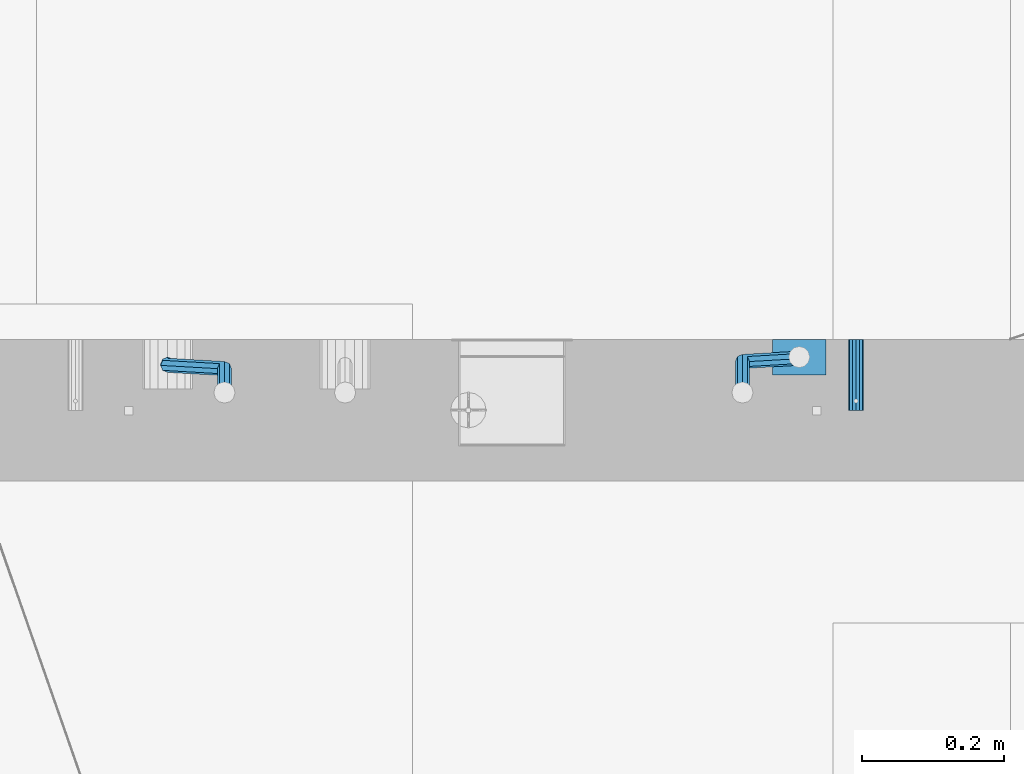
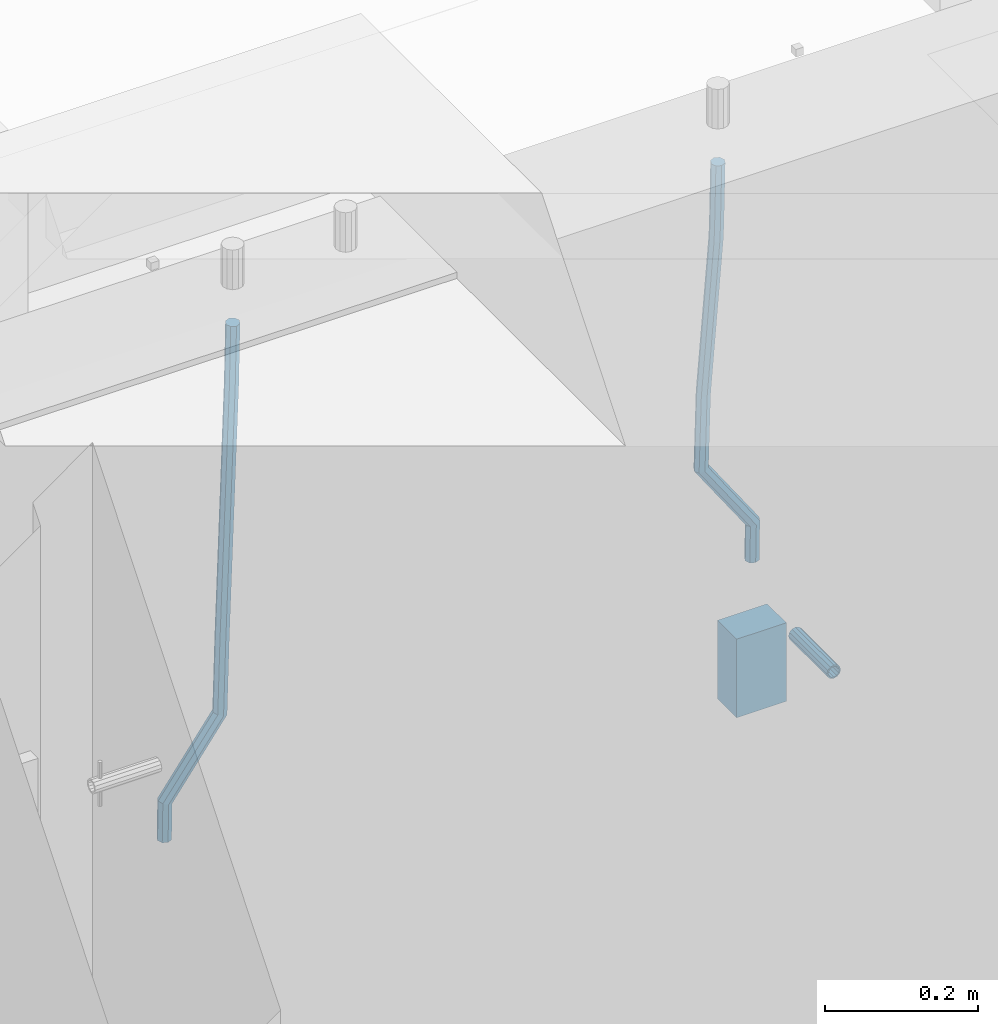
# One storey, part 164 of 352: 4 beams, 2 elements without a shape of their own.
"""IFC2X3 building model written with IfcOpenShell, lengths in millimetres."""

import ifcopenshell
import ifcopenshell.guid

model = None  # the IFC model being written
_history = None  # IfcOwnerHistory: only IFC2X3 demands one
_inside = {}  # id of a spatial element -> (the spatial element, [elements in it])
_under = {}  # id of a project, library or spatial element -> (it, [spatial elements below it])
_declared = {}  # id of a project -> (the project, [libraries it declares])
_typed = {}  # id of a type object -> (the type object, [elements of that type])
_made_of = {}  # id of a material, layer set ... -> (it, [elements and type objects made of it])


def new_model(schema):
    """Start an empty IFC model of exactly this schema.

    Asked for "IFC4X3", IfcOpenShell would pick the latest addendum, in which some entities
    have other attributes; the version numbers below select the first issue.
    IFC2X3 requires an IfcOwnerHistory on every rooted entity: one is made here for all.
    """
    global model, _history
    if schema == "IFC4X3":
        model = ifcopenshell.file(schema_version=(4, 3, 0, 0))
    else:
        model = ifcopenshell.file(schema=schema)
    _inside.clear()
    _under.clear()
    _declared.clear()
    _typed.clear()
    _made_of.clear()
    _history = None
    if model.schema == "IFC2X3":
        org = make("IfcOrganization", Name="unknown")
        user = make(
            "IfcPersonAndOrganization",
            ThePerson=make("IfcPerson", FamilyName="unknown"),
            TheOrganization=org,
        )
        app = make(
            "IfcApplication",
            ApplicationDeveloper=org,
            Version="unknown",
            ApplicationFullName="unknown",
            ApplicationIdentifier="unknown",
        )
        _history = make(
            "IfcOwnerHistory",
            OwningUser=user,
            OwningApplication=app,
            ChangeAction="ADDED",
            CreationDate=0,
        )
    return model


def make(cls, **values):
    """One entity of the class cls with the attributes given. An attribute that is None is left unset."""
    return model.create_entity(
        cls, **{name: value for name, value in values.items() if value is not None}
    )


def rooted(cls, **values):
    """An entity with a GlobalId (a new one), such as an element, a storey or a relation."""
    return make(cls, GlobalId=ifcopenshell.guid.new(), OwnerHistory=_history, **values)


def si_unit(unit_type, name, prefix=None):
    """IfcSIUnit, for example si_unit("LENGTHUNIT", "METRE", prefix="MILLI")."""
    return make("IfcSIUnit", UnitType=unit_type, Prefix=prefix, Name=name)


def assignment(units):
    """IfcUnitAssignment: the units of a project."""
    return None if units is None else make("IfcUnitAssignment", Units=units)


def point(xyz):
    """IfcCartesianPoint."""
    return None if xyz is None else make("IfcCartesianPoint", Coordinates=xyz)


def direction(xyz):
    """IfcDirection."""
    return None if xyz is None else make("IfcDirection", DirectionRatios=xyz)


def frame(location, z_axis=None, x_axis=None):
    """IfcAxis2Placement3D, a coordinate frame: its origin and axes. An axis left out is left unset."""
    return make(
        "IfcAxis2Placement3D",
        Location=point(location),
        Axis=direction(z_axis),
        RefDirection=direction(x_axis),
    )


def origin_with_axes():
    """The frame at (0, 0, 0) with the z axis (0, 0, 1) and the x axis (1, 0, 0) written out."""
    return frame((0.0, 0.0, 0.0), z_axis=(0.0, 0.0, 1.0), x_axis=(1.0, 0.0, 0.0))


def place(relative_to, where):
    """IfcLocalPlacement: puts the frame where relative to a parent placement (None: the world)."""
    return make(
        "IfcLocalPlacement", PlacementRelTo=relative_to, RelativePlacement=where
    )


def context(
    kind, dimensions, precision=None, world=None, true_north=None, identifier=None
):
    """IfcGeometricRepresentationContext, for example the 3D "Model" context."""
    return make(
        "IfcGeometricRepresentationContext",
        ContextIdentifier=identifier,
        ContextType=kind,
        CoordinateSpaceDimension=dimensions,
        Precision=precision,
        WorldCoordinateSystem=world,
        TrueNorth=true_north,
    )


def subcontext(parent, identifier, kind, view, scale=None):
    """IfcGeometricRepresentationSubContext, for example "Body" below "Model"."""
    return make(
        "IfcGeometricRepresentationSubContext",
        ContextIdentifier=identifier,
        ContextType=kind,
        ParentContext=parent,
        TargetScale=scale,
        TargetView=view,
    )


def project(units=None, contexts=None):
    """IfcProject with its units and contexts."""
    return rooted(
        "IfcProject",
        Name="project",
        RepresentationContexts=contexts,
        UnitsInContext=assignment(units),
    )


def spatial(cls, under=None, at=None, **own):
    """A site, building, storey or space (cls), placed at a placement, below another one or the project."""
    s = rooted(cls, ObjectPlacement=at, **own)
    if under is not None:
        _under.setdefault(under.id(), (under, []))[1].append(s)
    return s


def faces_of(points, faces, orient=None, outer=None):
    """IfcFace entities. A face is a list of loops; a loop is a list of indices into points, from 0.

    orient and outer hold one flag for each loop. By default every Orientation is true, the
    first loop of a face is its IfcFaceOuterBound and the others are IfcFaceBound.
    """
    made = []
    for i, loops in enumerate(faces):
        bounds = []
        for j, loop in enumerate(loops):
            is_outer = j == 0 if outer is None else outer[i][j]
            bounds.append(
                make(
                    "IfcFaceOuterBound" if is_outer else "IfcFaceBound",
                    Bound=make("IfcPolyLoop", Polygon=[points[k] for k in loop]),
                    Orientation=True if orient is None else orient[i][j],
                )
            )
        made.append(make("IfcFace", Bounds=bounds))
    return made


def faceted_brep(points, faces, orient=None, outer=None, voids=None):
    """IfcFacetedBrep: a solid bounded by flat faces; with voids (closed shells), ...WithVoids."""
    shared = [point(p) for p in points]
    hull = make("IfcClosedShell", CfsFaces=faces_of(shared, faces, orient, outer))
    if voids is None:
        return make("IfcFacetedBrep", Outer=hull)
    return make(
        "IfcFacetedBrepWithVoids",
        Outer=hull,
        Voids=[
            make(cls, CfsFaces=faces_of(shared, fs, o, b)) for cls, fs, o, b in voids
        ],
    )


def shape(context_of_items, identifier, shape_type, items):
    """IfcShapeRepresentation: the items that make up one representation, for example the "Body"."""
    return make(
        "IfcShapeRepresentation",
        ContextOfItems=context_of_items,
        RepresentationIdentifier=identifier,
        RepresentationType=shape_type,
        Items=items,
    )


def material(Name=None, Category=None):
    """IfcMaterial."""
    return make("IfcMaterial", Name=Name, Category=Category)


def made_of(thing, what):
    """Note that an element or type object is made of a material, layer set ...; save() writes the relation."""
    if what is not None:
        _made_of.setdefault(what.id(), (what, []))[1].append(thing)
    return thing


def type_object(cls, material=None, **own):
    """A type object (cls), such as IfcWallType, which elements share."""
    return made_of(rooted(cls, **own), material)


def element(
    cls,
    number,
    at=None,
    inside=None,
    cuts=None,
    type_object=None,
    material=None,
    context=None,
    identifier="Body",
    shape_type=None,
    held_by="IfcProductDefinitionShape",
    body=None,
    shapes=None,
    **own,
):
    """One element of the class cls, such as IfcWall. Its Tag is "e" and its number.

    at: its placement. inside: the storey or other place that contains it. cuts: it is an
    opening in that element (IfcRelVoidsElement). A single representation is given by context,
    identifier, shape_type and body (its items); several are given by shapes. held_by: the class
    of the entity that holds the representations. save() writes the other relations.
    """
    e = rooted(cls, Tag="e%d" % number, ObjectPlacement=at, **own)
    if body is not None:
        shapes = [shape(context, identifier, shape_type, body)]
    if shapes is not None:
        e.Representation = make(held_by, Representations=shapes)
    if inside is not None:
        _inside.setdefault(inside.id(), (inside, []))[1].append(e)
    if cuts is not None:
        rooted(
            "IfcRelVoidsElement", RelatingBuildingElement=cuts, RelatedOpeningElement=e
        )
    if type_object is not None:
        _typed.setdefault(type_object.id(), (type_object, []))[1].append(e)
    return made_of(e, material)


def aggregate(whole, parts):
    """IfcRelAggregates: a whole, such as a stair, and the parts it consists of."""
    return rooted("IfcRelAggregates", RelatingObject=whole, RelatedObjects=parts)


def save(model, path):
    """Write the relations noted so far, then the file.

    IfcRelAggregates (storeys below a building ...), IfcRelContainedInSpatialStructure (elements
    in a storey), IfcRelDefinesByType, IfcRelAssociatesMaterial and IfcRelDeclares: one each for
    every whole, place, type object, material and project.
    """
    for whole, parts in _under.values():
        aggregate(whole, parts)
    for where, things in _inside.values():
        rooted(
            "IfcRelContainedInSpatialStructure",
            RelatedElements=things,
            RelatingStructure=where,
        )
    for kind, things in _typed.values():
        rooted("IfcRelDefinesByType", RelatedObjects=things, RelatingType=kind)
    for what, things in _made_of.values():
        rooted("IfcRelAssociatesMaterial", RelatedObjects=things, RelatingMaterial=what)
    for by, libraries in _declared.values():
        rooted("IfcRelDeclares", RelatingContext=by, RelatedDefinitions=libraries)
    model.write(path)


model = new_model("IFC2X3")

# Units and contexts
model_context = context("Model", 3, precision=1e-05, world=origin_with_axes())
body_context = subcontext(model_context, "Body", "Model", "MODEL_VIEW")
ifc_project = project(units=[si_unit("LENGTHUNIT", "METRE", prefix="MILLI"), si_unit("AREAUNIT", "SQUARE_METRE"), si_unit("VOLUMEUNIT", "CUBIC_METRE"), si_unit("MASSUNIT", "GRAM", prefix="KILO"), si_unit("TIMEUNIT", "SECOND"), si_unit("PLANEANGLEUNIT", "RADIAN"), si_unit("SOLIDANGLEUNIT", "STERADIAN"), si_unit("THERMODYNAMICTEMPERATUREUNIT", "DEGREE_CELSIUS"), si_unit("LUMINOUSINTENSITYUNIT", "LUMEN")], contexts=[model_context])

# Site, building, storey
site_placement = place(None, origin_with_axes())
site = spatial("IfcSite", under=ifc_project, at=site_placement, CompositionType="ELEMENT")
building_placement = place(site_placement, origin_with_axes())
building = spatial("IfcBuilding", under=site, at=building_placement, CompositionType="ELEMENT")
storey_placement = place(building_placement, origin_with_axes())
storey = spatial("IfcBuildingStorey", under=building, at=storey_placement, Name="6", CompositionType="ELEMENT", Elevation=0.0)

# Assemblies, beams
assembly_1_placement = place(storey_placement, origin_with_axes())
assembly_1 = element("IfcElementAssembly", 1, at=assembly_1_placement, inside=storey, AssemblyPlace="NOTDEFINED", PredefinedType="REINFORCEMENT_UNIT")
assembly_2_placement = place(assembly_1_placement, origin_with_axes())
assembly_2 = element("IfcElementAssembly", 2, at=assembly_2_placement, Name="Steel Assembly", AssemblyPlace="NOTDEFINED", PredefinedType="RIGID_FRAME")
ifc_material_1 = material(Name="STEEL/Steel_Undefined")
beam_type_1 = type_object("IfcBeamType", PredefinedType="NOTDEFINED")
beam_1_placement = place(assembly_2_placement, frame((27934.9999668009, 17080.0, 98555.0), z_axis=(1.0, 0.0, 0.0), x_axis=(0.0, -1.0, 0.0)))
beam_1 = element("IfcBeam", 3, at=beam_1_placement, type_object=beam_type_1, material=ifc_material_1, Name="M16", context=body_context, shape_type="Brep", body=[
    faceted_brep([(0.0, -8.49999999999272, -1.45519152283669e-11), (0.0, -7.36121593215648, 4.24999999998545), (100.000000000262, -7.36121593215648, 4.24999999998545), (100.000000000262, -8.49999999999272, -1.45519152283669e-11), (0.0, -4.24999999998545, 7.36121593216376), (100.000000000262, -4.24999999998545, 7.36121593216376), (0.0, 1.45519152283669e-11, 8.49999999998545), (100.000000000262, 1.45519152283669e-11, 8.49999999998545), (0.0, 4.25000000001455, 7.36121593216376), (100.000000000262, 4.25000000001455, 7.36121593216376), (0.0, 7.36121593217104, 4.24999999998545), (100.000000000262, 7.36121593217104, 4.24999999998545), (0.0, 8.50000000000728, 0.0), (100.000000000262, 8.50000000000728, 0.0), (0.0, 7.36121593217104, -4.25000000001455), (100.000000000262, 7.36121593217104, -4.25000000001455), (0.0, 4.25000000000728, -7.36121593219286), (100.000000000262, 4.25000000000728, -7.36121593219286), (0.0, 7.27595761418343e-12, -8.5), (100.000000000262, 7.27595761418343e-12, -8.5), (0.0, -4.24999999999272, -7.36121593217831), (100.000000000262, -4.24999999999272, -7.36121593217831), (0.0, -7.36121593215648, -4.25), (100.000000000262, -7.36121593215648, -4.25), (0.0, -10.4999999999927, -1.45519152283669e-11), (0.0, -9.09326673972828, -5.25000000001455), (100.000000000262, -9.09326673972828, -5.25000000001455), (100.000000000262, -10.4999999999927, -1.45519152283669e-11), (0.0, -5.24999999998545, -9.09326673974283), (100.000000000262, -5.24999999998545, -9.09326673974283), (0.0, 7.27595761418343e-12, -10.5), (100.000000000262, 7.27595761418343e-12, -10.5), (0.0, 5.25000000001455, -9.09326673975738), (100.000000000262, 5.25000000001455, -9.09326673975738), (0.0, 9.09326673975011, -5.25000000001455), (100.000000000262, 9.09326673975011, -5.25000000001455), (0.0, 10.5000000000073, -1.45519152283669e-11), (100.000000000262, 10.5000000000073, -1.45519152283669e-11), (0.0, 9.09326673975011, 5.25), (100.000000000262, 9.09326673975011, 5.25), (0.0, 5.25000000000728, 9.09326673972828), (100.000000000262, 5.25000000000728, 9.09326673972828), (0.0, 1.45519152283669e-11, 10.4999999999854), (100.000000000262, 1.45519152283669e-11, 10.4999999999854), (0.0, -5.24999999999272, 9.09326673972828), (100.000000000262, -5.24999999999272, 9.09326673972828), (0.0, -9.09326673972828, 5.24999999998545), (100.000000000262, -9.09326673972828, 5.24999999998545)], [[[0, 1, 2, 3]], [[1, 4, 5, 2]], [[4, 6, 7, 5]], [[6, 8, 9, 7]], [[8, 10, 11, 9]], [[10, 12, 13, 11]], [[12, 14, 15, 13]], [[14, 16, 17, 15]], [[16, 18, 19, 17]], [[18, 20, 21, 19]], [[20, 22, 23, 21]], [[22, 0, 3, 23]], [[24, 25, 26, 27]], [[25, 28, 29, 26]], [[28, 30, 31, 29]], [[30, 32, 33, 31]], [[32, 34, 35, 33]], [[34, 36, 37, 35]], [[36, 38, 39, 37]], [[38, 40, 41, 39]], [[40, 42, 43, 41]], [[42, 44, 45, 43]], [[44, 46, 47, 45]], [[46, 24, 27, 47]], [[29, 31, 33, 35, 37, 39, 41, 43, 45, 47, 27, 26], [5, 7, 9, 11, 13, 15, 17, 19, 21, 23, 3, 2]], [[46, 44, 42, 40, 38, 36, 34, 32, 30, 28, 25, 24], [22, 20, 18, 16, 14, 12, 10, 8, 6, 4, 1, 0]]]),
])
aggregate(assembly_2, [beam_1])
ifc_material_2 = material()
beam_type_2 = type_object("IfcBeamType", Name="D20", PredefinedType="NOTDEFINED")
beam_2_placement = place(assembly_1_placement, frame((27854.9999105249, 17055.0000022791, 98717.5), z_axis=(0.00020576299992186, -0.999642804629538, -0.0267249099901004), x_axis=(-4.30000201928125e-08, -0.0267249099948059, 0.999642825806181)))
beam_2 = element("IfcBeam", 4, at=beam_2_placement, type_object=beam_type_2, material=ifc_material_2, Name="JM20", ObjectType="D20", context=body_context, shape_type="Brep", body=[
    faceted_brep([(0.0, -10.0, 0.0), (-4.19531716033816e-08, -7.07106781186667, -7.07106781187031), (57.3778003524785, -7.07106779628884, -7.0710678060168), (57.3778003565822, -9.99999998442945, 5.84986992180347e-09), (0.0, 0.0, -10.0), (57.3778003491898, 1.55741872731596e-08, -9.99999999415013), (4.196772351861e-08, 7.07106781186303, -7.07106781186667), (57.3778003486368, 7.07106782744086, -7.0710678060168), (0.0, 10.0, 0.0), (57.3778003511543, 10.0000000155705, 5.84986992180347e-09), (4.196772351861e-08, 7.07106781185939, 7.07106781185939), (57.3778003552725, 7.07106782744086, 7.0710678177129), (0.0, 0.0, 10.0), (57.3778003585467, 1.55741872731596e-08, 10.0000000058535), (-4.19531716033816e-08, -7.07106781187031, 7.07106781185939), (57.3778003591142, -7.07106779628884, 7.0710678177129), (63.2348501311644, -7.07106779493188, -7.07106780540926), (64.1057957623998, -9.99999998283238, 6.54472387395799e-09), (61.04994790192, 1.63490767590702e-08, -9.99999999377178), (58.8309751681372, 7.07106782761548, -7.07106780586037), (57.8777760627127, 10.0000000155014, 5.90807758271694e-09), (58.7487216939626, 7.07106782759729, 7.07106781786206), (60.9336239231925, 1.63163349498063e-08, 10.0000000062173), (63.1525966569752, -7.07106779495371, 7.07106781830953), (68.0560815638019, -3.74583294561307, -7.00896065082998), (69.6439432500047, -6.18030344188082, 0.0713424813729944), (64.0726841869619, 2.08480100043016, -9.96106107280502), (60.0271712784888, 7.89609210789058, -7.05565839484916), (58.2893494334276, 10.283864860914, 0.00530189843993867), (59.8772111196158, 7.84939436464629, 7.08560503063927), (63.8606084964704, 2.01876041860305, 10.037705452618), (67.9061214049289, -3.79253068885737, 7.13230277466573), (178.098456601496, 72.1511127806843, -5.59139360533663), (179.686318287684, 69.716642284413, 1.48890952685906), (174.115059224641, 77.9817467267239, -8.54349402731532), (170.069546316168, 83.7930378341844, -5.63809134935946), (168.331724471092, 86.1808105872078, 1.42286894392964), (169.91958615731, 83.7463400909437, 8.50317207612898), (173.90298353415, 77.9157061448968, 11.455272498104), (177.948496442623, 72.1044150374437, 8.5498698201518), (179.289255982527, 72.9724149014583, -5.57605371504542), (180.097891658399, 70.0005071298292, 1.4942114193982), (177.129995245661, 80.0611678177193, -8.50465558942597), (174.884975102759, 87.1142705605816, -5.5760589445199), (173.869297905752, 90.00011120009, 1.49420402380565), (174.67793358161, 87.0282034284573, 8.5644691582529), (176.837194318476, 79.9394505121963, 11.4930710326298), (179.082214461378, 72.8863477693376, 8.56447438772739), (180.735622590379, 72.972420835973, -5.54778204405011), (180.597796167538, 70.0005091809617, 1.50398289485383), (180.791991426609, 80.0611828430738, -8.4330757073476), (180.733882576489, 87.1142945589418, -5.46173219850607), (180.595335416292, 90.0001387973534, 1.62567575346111), (180.457508993451, 87.0282271423457, 8.67744069236505), (180.401140157206, 79.939465135245, 11.5627343556625), (180.459249007356, 72.8863534193733, 8.59139084682101), (299.223827734662, 72.9729069989553, -3.23173054285144), (299.086001311836, 70.0009953439476, 3.82003439605251), (299.280196570893, 80.0616690060597, -6.11702420615256), (299.222087720773, 87.1147807219277, -3.14568069731467), (299.083540560576, 90.0006249603393, 3.94172725465251), (298.945714137735, 87.0287133053316, 10.9934921935564), (298.889345301504, 79.9399512982272, 13.8787858568576), (298.947454151639, 72.8868395823556, 10.9074423480197), (300.386274806908, 72.9729117685347, -3.20900855728542), (299.975441269635, 70.0009989933678, 3.8374199978316), (300.554299891708, 80.0616742337661, -6.09211971118202), (300.381089708186, 87.1147854773699, -3.12302605173682), (299.968108432717, 90.0006285897653, 3.95901762330686), (299.557274895458, 87.0287158145948, 11.0054461784239), (299.389249810658, 79.9399533493597, 13.8885573323169), (299.562459994166, 72.8868421057559, 10.9194636728716), (301.54348499664, 72.972935138263, -3.09647384826167), (300.860874255726, 70.0010168745794, 3.92352530897551), (301.822663312996, 80.0616998482183, -5.96877573286474), (301.534870333402, 87.1148087778347, -3.01082485606094), (300.848691282124, 90.0006463730351, 4.04465127535514), (300.166080541225, 87.0287281093551, 11.0646504325923), (299.886902224855, 79.9399633993926, 13.9369523171918), (300.174695204449, 72.8868544697798, 10.9790014403879), (567.277632096637, 72.9783016087349, 22.7452575737989), (566.595021355723, 70.0063833450513, 29.7652567310361), (567.556810412992, 80.0670663186975, 19.8729556891958), (567.269017433413, 87.1201752483139, 22.8309065659996), (566.582838382135, 90.0060128435071, 29.886382697412), (565.900227641221, 87.0340945798234, 36.9063818546456), (565.621049324851, 79.9453298698681, 39.7786837392523), (565.90884230446, 72.8922209402554, 36.8207328624449), (567.849310941645, 72.9783131537188, 22.8008513743443), (567.441064932689, 70.0064004308078, 29.8475315576834), (568.054462827218, 80.0670763687303, 19.9213506740707), (567.93634539716, 87.1201887249226, 22.8958019142228), (567.564150240039, 90.0060326609891, 29.9818118989315), (567.155904231084, 87.0341199380709, 37.0284920822669), (566.950752345525, 79.9453567230667, 39.9079927825405), (567.068869775569, 72.8922443668707, 36.9335415423957), (568.423586898687, 72.9708243880268, 22.8084944200891), (568.290952048657, 69.9953175961527, 29.8588427157192), (568.554376054599, 80.0605573198627, 19.9280040253361), (568.606705002705, 87.1114469937784, 22.9047237384184), (568.549920154881, 89.9931778656028, 29.9949315228005), (568.417285304851, 87.0176710737251, 37.0452798184269), (568.286496148939, 79.9279381418964, 39.9257702131799), (568.234167200833, 72.8770484679771, 36.9490505000977), (589.912124239258, 72.6906061074042, 23.0944856267633), (589.779489389242, 69.7150993155265, 30.1448339223862), (590.042913395198, 79.7803390392328, 20.2139952320067), (590.095242343275, 86.8312287131521, 23.190714945089), (590.038457495451, 89.7129595849765, 30.2809227294711), (589.905822645451, 86.7374527930988, 37.3312710250975), (589.775033489525, 79.6477198612702, 40.2117614198505), (589.722704541418, 72.5968301873472, 37.2350417067682), (590.547165551296, 72.6823249395493, 23.1029373993588), (590.439554471668, 69.7064918286778, 30.1536187366546), (590.620682129796, 79.7728047264573, 20.2216847631717), (590.617039192599, 86.8244242939545, 23.197659545749), (590.538370722847, 89.7064405361089, 30.2875760807365), (590.430759643248, 86.7306074252338, 37.3382574180287), (590.357243064718, 79.6401276383258, 40.2195100542194), (590.36088600193, 72.5885080708285, 37.243535271642), (591.182260594243, 72.6841934809891, 23.1112002334121), (591.099675200006, 69.7084600799535, 30.1622167658497), (591.198500084778, 79.7744922147613, 20.2291794306657), (591.138880798317, 86.8259554442993, 23.2044030568104), (591.038326904265, 89.7079316443269, 30.2940254627501), (590.955741510043, 86.7321982432914, 37.3450419951805), (590.939502019522, 79.6418995095191, 40.2270627979342), (590.999121305984, 72.5904362799774, 37.2518391717822), (691.203058405095, 72.9824563748625, 24.4085746238379), (691.120473010888, 70.0067229738306, 31.4595911562756), (691.219297895645, 80.0727551086347, 21.5265538210951), (691.159678609169, 87.1242183381728, 24.5017774472362), (691.059124715146, 90.0061945381967, 31.591399853176), (690.976539320895, 87.0304611371721, 38.6424163856136), (690.960299830374, 79.9401624033926, 41.5244371883564), (691.019919116836, 72.8886991738545, 38.5492135622153)], [[[0, 1, 2, 3]], [[1, 4, 5, 2]], [[4, 6, 7, 5]], [[6, 8, 9, 7]], [[8, 10, 11, 9]], [[10, 12, 13, 11]], [[12, 14, 15, 13]], [[14, 0, 3, 15]], [[14, 12, 10, 8, 6, 4, 1, 0]], [[3, 2, 16, 17]], [[2, 5, 18, 16]], [[5, 7, 19, 18]], [[7, 9, 20, 19]], [[9, 11, 21, 20]], [[11, 13, 22, 21]], [[13, 15, 23, 22]], [[15, 3, 17, 23]], [[17, 16, 24, 25]], [[16, 18, 26, 24]], [[18, 19, 27, 26]], [[19, 20, 28, 27]], [[20, 21, 29, 28]], [[21, 22, 30, 29]], [[22, 23, 31, 30]], [[23, 17, 25, 31]], [[25, 24, 32, 33]], [[24, 26, 34, 32]], [[26, 27, 35, 34]], [[27, 28, 36, 35]], [[28, 29, 37, 36]], [[29, 30, 38, 37]], [[30, 31, 39, 38]], [[31, 25, 33, 39]], [[33, 32, 40, 41]], [[32, 34, 42, 40]], [[34, 35, 43, 42]], [[35, 36, 44, 43]], [[36, 37, 45, 44]], [[37, 38, 46, 45]], [[38, 39, 47, 46]], [[39, 33, 41, 47]], [[41, 40, 48, 49]], [[40, 42, 50, 48]], [[42, 43, 51, 50]], [[43, 44, 52, 51]], [[44, 45, 53, 52]], [[45, 46, 54, 53]], [[46, 47, 55, 54]], [[47, 41, 49, 55]], [[49, 48, 56, 57]], [[48, 50, 58, 56]], [[50, 51, 59, 58]], [[51, 52, 60, 59]], [[52, 53, 61, 60]], [[53, 54, 62, 61]], [[54, 55, 63, 62]], [[55, 49, 57, 63]], [[57, 56, 64, 65]], [[56, 58, 66, 64]], [[58, 59, 67, 66]], [[59, 60, 68, 67]], [[60, 61, 69, 68]], [[61, 62, 70, 69]], [[62, 63, 71, 70]], [[63, 57, 65, 71]], [[65, 64, 72, 73]], [[64, 66, 74, 72]], [[66, 67, 75, 74]], [[67, 68, 76, 75]], [[68, 69, 77, 76]], [[69, 70, 78, 77]], [[70, 71, 79, 78]], [[71, 65, 73, 79]], [[73, 72, 80, 81]], [[72, 74, 82, 80]], [[74, 75, 83, 82]], [[75, 76, 84, 83]], [[76, 77, 85, 84]], [[77, 78, 86, 85]], [[78, 79, 87, 86]], [[79, 73, 81, 87]], [[81, 80, 88, 89]], [[80, 82, 90, 88]], [[82, 83, 91, 90]], [[83, 84, 92, 91]], [[84, 85, 93, 92]], [[85, 86, 94, 93]], [[86, 87, 95, 94]], [[87, 81, 89, 95]], [[89, 88, 96, 97]], [[88, 90, 98, 96]], [[90, 91, 99, 98]], [[91, 92, 100, 99]], [[92, 93, 101, 100]], [[93, 94, 102, 101]], [[94, 95, 103, 102]], [[95, 89, 97, 103]], [[97, 96, 104, 105]], [[96, 98, 106, 104]], [[98, 99, 107, 106]], [[99, 100, 108, 107]], [[100, 101, 109, 108]], [[101, 102, 110, 109]], [[102, 103, 111, 110]], [[103, 97, 105, 111]], [[105, 104, 112, 113]], [[104, 106, 114, 112]], [[106, 107, 115, 114]], [[107, 108, 116, 115]], [[108, 109, 117, 116]], [[109, 110, 118, 117]], [[110, 111, 119, 118]], [[111, 105, 113, 119]], [[113, 112, 120, 121]], [[112, 114, 122, 120]], [[114, 115, 123, 122]], [[115, 116, 124, 123]], [[116, 117, 125, 124]], [[117, 118, 126, 125]], [[118, 119, 127, 126]], [[119, 113, 121, 127]], [[121, 120, 128, 129]], [[120, 122, 130, 128]], [[122, 123, 131, 130]], [[123, 124, 132, 131]], [[124, 125, 133, 132]], [[125, 126, 134, 133]], [[126, 127, 135, 134]], [[127, 121, 129, 135]], [[130, 131, 132, 133, 134, 135, 129, 128]]]),
])
beam_3_placement = place(assembly_1_placement, frame((26964.9999105249, 17045.0000022791, 98590.0), z_axis=(0.00020576299992186, -0.999642804629538, -0.0267249099901004), x_axis=(-4.30000201928125e-08, -0.0267249099948059, 0.999642825806181)))
beam_3 = element("IfcBeam", 5, at=beam_3_placement, type_object=beam_type_2, material=ifc_material_2, Name="JM20", ObjectType="D20", context=body_context, shape_type="Brep", body=[
    faceted_brep([(0.0, -10.0, 0.0), (-4.19531716033816e-08, -7.07106781186667, -7.07106781187031), (57.3778003524785, -7.07106779628884, -7.0710678060168), (57.3778003565822, -9.99999998442945, 5.84986992180347e-09), (0.0, 0.0, -10.0), (57.3778003491898, 1.55741872731596e-08, -9.99999999415013), (4.196772351861e-08, 7.07106781186303, -7.07106781186667), (57.3778003486368, 7.07106782744086, -7.0710678060168), (0.0, 10.0, 0.0), (57.3778003511543, 10.0000000155705, 5.84986992180347e-09), (4.196772351861e-08, 7.07106781185939, 7.07106781185939), (57.3778003552725, 7.07106782744086, 7.0710678177129), (0.0, 0.0, 10.0), (57.3778003585467, 1.55741872731596e-08, 10.0000000058535), (-4.19531716033816e-08, -7.07106781187031, 7.07106781185939), (57.3778003591142, -7.07106779628884, 7.0710678177129), (58.8318985002552, -7.07106779589958, -7.07106780586764), (57.8778003565822, -9.99999998429485, 5.90443960390985e-09), (61.0512293968495, 1.65709934663028e-08, -9.99999999377542), (63.2357391065598, 7.07106782902702, -7.07106780541653), (64.1057714685594, 10.0000000174005, 6.53744791634381e-09), (63.1516733248864, 7.07106782900519, 7.07106781830589), (60.932342428292, 1.65382516570389e-08, 10.0000000062137), (58.7478327185672, -7.07106779591777, 7.07106781785842), (60.0288346662128, -7.89659605236375, -7.05530913284747), (58.2893737320846, -10.2838626168559, 0.0054187161331356), (64.075000582452, -2.08549846343158, -9.96018949865174), (68.0576823626325, 3.74536799461202, -7.00758286006021), (69.6438790345856, 6.18036083103652, 0.0729138583883469), (67.9044181004574, 3.79309426654072, 7.13364170736895), (63.8582521842327, -2.01800332238781, 10.0385220731696), (59.8755704040377, -7.84886978043505, 7.08591543458169), (170.071205978675, -83.7929466763271, -5.60650860604073), (168.331745044532, -86.1802132408156, 1.45421924293987), (174.117371894885, -77.9818490873949, -8.51138897184137), (178.100053675094, -72.150982629355, -5.55878233325711), (179.686250347047, -69.7159897929341, 1.52171438519144), (177.946789412905, -72.1032563574299, 8.58244223417205), (173.90062349668, -77.9143539463585, 11.4873225999763), (169.9179417165, -83.7452204043984, 8.53471596138843), (174.885917629814, -87.1136588644658, -5.54311887085714), (173.869352081325, -89.9995072115853, 1.52712650490139), (177.131269974328, -80.0605380746747, -8.47170846447989), (179.290112163741, -72.9717673438317, -5.54311421065358), (180.09782372255, -69.9998524254988, 1.52713309542378), (179.081258174047, -72.8857007726183, 8.59737847118231), (176.835905829546, -79.9388215623985, 11.5259680648051), (174.677063640134, -87.0275922932524, 8.59737381097511), (180.733953989722, -87.1136352324538, -5.42880915215937), (180.595430327434, -89.999480031398, 1.65859903088131), (180.792005409938, -80.0605232815869, -8.40015322574254), (180.735578853404, -72.9717615026784, -5.51486013004978), (180.597728231689, -69.9998504053765, 1.53690457089033), (180.459204569401, -72.885695204317, 8.62431275393101), (180.401153149185, -79.9388071551803, 11.5956568275142), (180.457579705719, -87.0275689340961, 8.71036373181778), (299.547258407722, -87.113155105988, -3.10640303667606), (299.408734745448, -89.9989999049212, 3.98100514636099), (299.605309827937, -80.0600431551138, -6.07774711026286), (299.548883271418, -72.9712813762017, -3.1924540145701), (299.411032649703, -69.9993702789034, 3.85931068637365), (299.2725089874, -72.8852150778403, 10.9467188694071), (299.214457567214, -79.9383270287144, 13.9180629429939), (299.270884123718, -87.0270888076229, 11.0327698472975), (300.152711613046, -87.1131526593381, -3.09456843420048), (299.970255028908, -89.998997635812, 3.99198100589638), (300.229173865737, -80.0600406340709, -6.06555263706105), (300.154851236337, -72.9712789274818, -3.18060935024914), (299.973280913182, -69.999368006851, 3.87030077550298), (299.790824329029, -72.8852129833249, 10.9568502155962), (299.714362076353, -79.9383250085921, 13.9278344184604), (299.788684705738, -87.0270867151812, 11.0428911316449), (300.757971557832, -87.1131486122868, -3.07522829750815), (300.53159607522, -89.9989938824292, 4.0099177827542), (300.852838766252, -80.0600364639577, -6.04562439873916), (300.760625776413, -72.9712748769889, -3.16125277046012), (300.535349707119, -69.9993642486006, 3.88826080639774), (300.308974224507, -72.8852095187322, 10.9734068866528), (300.214107016072, -79.9383216670649, 13.9438029878838), (300.306320005926, -87.0270832540336, 11.0594313596121), (694.302737300924, -87.1105171895797, 9.49988035006754), (694.076361818312, -89.9963624597149, 16.585026430319), (694.397604509359, -80.0574050412542, 6.52948424883652), (694.305391519505, -72.9686434542782, 9.41385587710465), (694.080115450226, -69.9967328258899, 16.4633694539662), (693.853739967599, -72.8825780960215, 23.5485155342212), (693.758872759179, -79.9356902443542, 26.5189116354522), (693.851085749033, -87.0244518313229, 23.6345400071805), (694.802482240659, -87.1105138480525, 9.51584891948733), (694.623303945409, -89.9963588026076, 16.6025031121862), (694.915659771606, -80.0574015772909, 6.54603789603061), (694.896538675588, -72.968639501596, 9.4327450616729), (694.756319831315, -69.996728304468, 16.4849765093786), (694.57714153605, -72.8825732590267, 23.5716307020812), (694.463964005088, -79.9356855297883, 26.5414417255342), (694.483085101121, -87.0244476054831, 23.6547345598919), (695.302395468068, -87.1170328969201, 9.52250227075638), (695.170430253667, -90.0034935270887, 16.6097848229292), (695.433889487511, -80.064159479778, 6.55293502166751), (695.487884898772, -72.9763508697215, 9.44061529579994), (695.432751922272, -70.0055492230131, 16.4939791523611), (695.30078670787, -72.892009853178, 23.581261704534), (695.169292688428, -79.9448832703201, 26.5508289536265), (695.115297277152, -87.0326918803803, 23.6631486794868), (717.096960509152, -87.4012418891907, 9.81256640384163), (716.96499529478, -90.2877025193593, 16.8998489560108), (717.228454528595, -80.3483684720522, 6.84299915475276), (717.28244993987, -73.2605598619884, 9.73067942887792), (717.227316963355, -70.2897582152873, 16.7840432854464), (717.095351748983, -73.1762188454522, 23.8713258376192), (716.963857729526, -80.2290922625871, 26.8408930867081), (716.909862318265, -87.3169008726472, 23.9532128125757), (717.732752035779, -87.4095328401163, 9.82102816105544), (717.62510360773, -90.2963105699491, 16.9086343456293), (717.807253658262, -80.3559162215497, 6.85070239946072), (717.804966435171, -73.2673736656325, 9.73763360732119), (717.727230190765, -70.2962772641549, 16.7906966367118), (717.61958176273, -73.1830549939841, 23.8783028212929), (717.545080140233, -80.2366716125471, 26.8486285828913), (717.547367363324, -87.3252141684679, 23.9616973750308), (718.368597467226, -87.4076503896285, 9.82928955306488), (718.285267778789, -90.2943418380746, 16.9172167822726), (718.386102043136, -80.3542095057164, 6.85821078440495), (718.327527563335, -73.2658291947409, 9.74439812407945), (718.227186163713, -70.2947865076021, 16.7971621720717), (718.143856475261, -73.1814779560518, 23.885089401283), (718.126351899366, -80.2349188399603, 26.8561681699393), (718.184926379137, -87.3232991509467, 23.9699808302648), (818.389373660975, -87.1093875602128, 11.1266636631008), (818.306043972552, -89.9960790086589, 18.2145908923085), (818.4068782369, -80.0559466763007, 8.1555848944372), (818.348303757099, -72.9675663653215, 11.0417722341153), (818.247962357447, -69.9965236781827, 18.0945362821076), (818.16463266901, -72.8832151266324, 25.1824635113153), (818.1471280931, -79.9366560105409, 28.1535422799789), (818.205702572901, -87.0250363215273, 25.2673549403007)], [[[0, 1, 2, 3]], [[1, 4, 5, 2]], [[4, 6, 7, 5]], [[6, 8, 9, 7]], [[8, 10, 11, 9]], [[10, 12, 13, 11]], [[12, 14, 15, 13]], [[14, 0, 3, 15]], [[14, 12, 10, 8, 6, 4, 1, 0]], [[3, 2, 16, 17]], [[2, 5, 18, 16]], [[5, 7, 19, 18]], [[7, 9, 20, 19]], [[9, 11, 21, 20]], [[11, 13, 22, 21]], [[13, 15, 23, 22]], [[15, 3, 17, 23]], [[17, 16, 24, 25]], [[16, 18, 26, 24]], [[18, 19, 27, 26]], [[19, 20, 28, 27]], [[20, 21, 29, 28]], [[21, 22, 30, 29]], [[22, 23, 31, 30]], [[23, 17, 25, 31]], [[25, 24, 32, 33]], [[24, 26, 34, 32]], [[26, 27, 35, 34]], [[27, 28, 36, 35]], [[28, 29, 37, 36]], [[29, 30, 38, 37]], [[30, 31, 39, 38]], [[31, 25, 33, 39]], [[33, 32, 40, 41]], [[32, 34, 42, 40]], [[34, 35, 43, 42]], [[35, 36, 44, 43]], [[36, 37, 45, 44]], [[37, 38, 46, 45]], [[38, 39, 47, 46]], [[39, 33, 41, 47]], [[41, 40, 48, 49]], [[40, 42, 50, 48]], [[42, 43, 51, 50]], [[43, 44, 52, 51]], [[44, 45, 53, 52]], [[45, 46, 54, 53]], [[46, 47, 55, 54]], [[47, 41, 49, 55]], [[49, 48, 56, 57]], [[48, 50, 58, 56]], [[50, 51, 59, 58]], [[51, 52, 60, 59]], [[52, 53, 61, 60]], [[53, 54, 62, 61]], [[54, 55, 63, 62]], [[55, 49, 57, 63]], [[57, 56, 64, 65]], [[56, 58, 66, 64]], [[58, 59, 67, 66]], [[59, 60, 68, 67]], [[60, 61, 69, 68]], [[61, 62, 70, 69]], [[62, 63, 71, 70]], [[63, 57, 65, 71]], [[65, 64, 72, 73]], [[64, 66, 74, 72]], [[66, 67, 75, 74]], [[67, 68, 76, 75]], [[68, 69, 77, 76]], [[69, 70, 78, 77]], [[70, 71, 79, 78]], [[71, 65, 73, 79]], [[73, 72, 80, 81]], [[72, 74, 82, 80]], [[74, 75, 83, 82]], [[75, 76, 84, 83]], [[76, 77, 85, 84]], [[77, 78, 86, 85]], [[78, 79, 87, 86]], [[79, 73, 81, 87]], [[81, 80, 88, 89]], [[80, 82, 90, 88]], [[82, 83, 91, 90]], [[83, 84, 92, 91]], [[84, 85, 93, 92]], [[85, 86, 94, 93]], [[86, 87, 95, 94]], [[87, 81, 89, 95]], [[89, 88, 96, 97]], [[88, 90, 98, 96]], [[90, 91, 99, 98]], [[91, 92, 100, 99]], [[92, 93, 101, 100]], [[93, 94, 102, 101]], [[94, 95, 103, 102]], [[95, 89, 97, 103]], [[97, 96, 104, 105]], [[96, 98, 106, 104]], [[98, 99, 107, 106]], [[99, 100, 108, 107]], [[100, 101, 109, 108]], [[101, 102, 110, 109]], [[102, 103, 111, 110]], [[103, 97, 105, 111]], [[105, 104, 112, 113]], [[104, 106, 114, 112]], [[106, 107, 115, 114]], [[107, 108, 116, 115]], [[108, 109, 117, 116]], [[109, 110, 118, 117]], [[110, 111, 119, 118]], [[111, 105, 113, 119]], [[113, 112, 120, 121]], [[112, 114, 122, 120]], [[114, 115, 123, 122]], [[115, 116, 124, 123]], [[116, 117, 125, 124]], [[117, 118, 126, 125]], [[118, 119, 127, 126]], [[119, 113, 121, 127]], [[121, 120, 128, 129]], [[120, 122, 130, 128]], [[122, 123, 131, 130]], [[123, 124, 132, 131]], [[124, 125, 133, 132]], [[125, 126, 134, 133]], [[126, 127, 135, 134]], [[127, 121, 129, 135]], [[130, 131, 132, 133, 134, 135, 129, 128]]]),
])
beam_type_3 = type_object("IfcBeamType", PredefinedType="NOTDEFINED")
beam_4_placement = place(assembly_1_placement, frame((27892.4999105288, 17055.0, 98555.0), z_axis=(0.0, 0.0, 1.0), x_axis=(-1.0, 3.00000001838171e-08, 0.0)))
beam_4 = element("IfcBeam", 6, at=beam_4_placement, type_object=beam_type_3, material=ifc_material_2, Name="WM1", context=body_context, shape_type="Brep", body=[
    faceted_brep([(0.0, 25.0, -62.5), (0.0, 25.0, 62.5), (75.0, 25.0, 62.5), (75.0, 25.0, -62.5), (0.0, -25.0, 62.5), (75.0, -25.0, 62.5), (0.0, -25.0, -62.5), (75.0, -25.0, -62.5)], [[[0, 1, 2, 3]], [[1, 4, 5, 2]], [[4, 6, 7, 5]], [[6, 0, 3, 7]], [[5, 7, 3, 2]], [[0, 6, 4, 1]]]),
])
aggregate(assembly_1, [assembly_2, beam_2, beam_4, beam_3])

save(model, "model.ifc")
